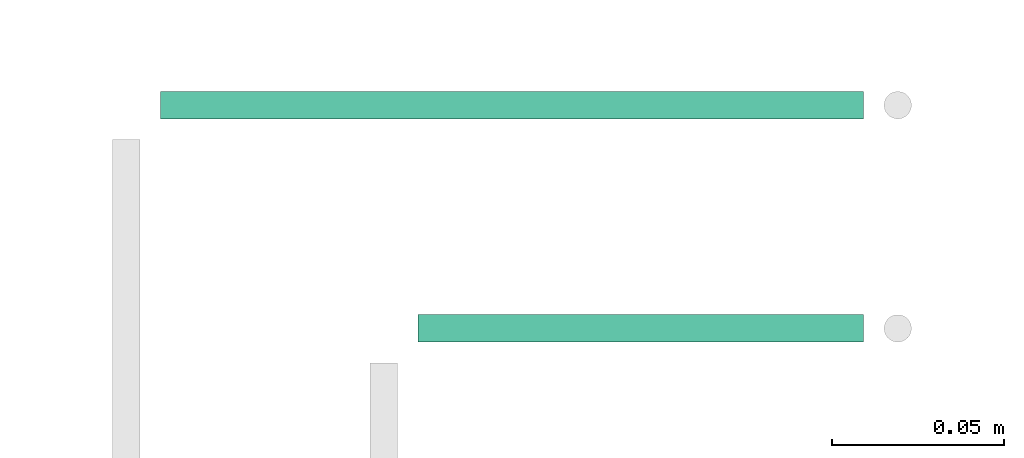
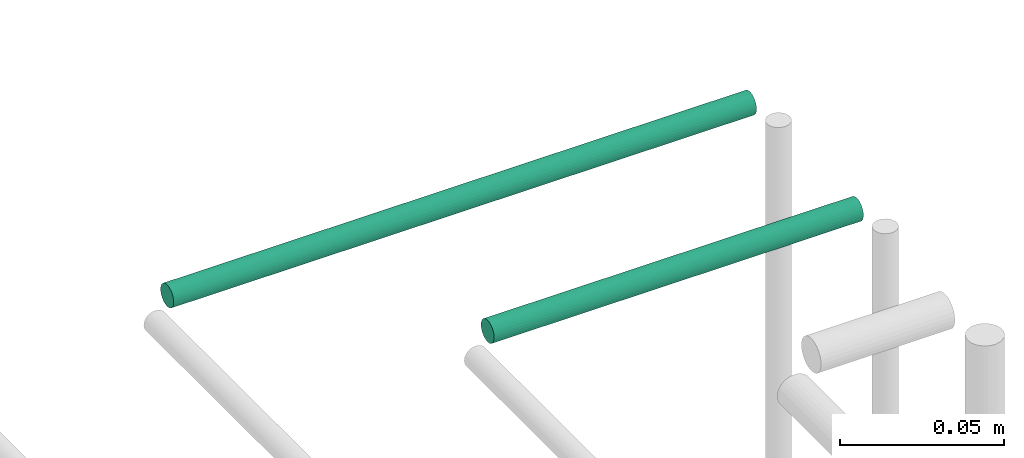
# One storey, part 239 of 331: 2 flow segments.
"""IFC2X3 building model written with IfcOpenShell, lengths in millimetres."""

import ifcopenshell
import ifcopenshell.guid

model = None  # the IFC model being written
_history = None  # IfcOwnerHistory: only IFC2X3 demands one
_inside = {}  # id of a spatial element -> (the spatial element, [elements in it])
_under = {}  # id of a project, library or spatial element -> (it, [spatial elements below it])
_declared = {}  # id of a project -> (the project, [libraries it declares])
_typed = {}  # id of a type object -> (the type object, [elements of that type])
_made_of = {}  # id of a material, layer set ... -> (it, [elements and type objects made of it])


def new_model(schema):
    """Start an empty IFC model of exactly this schema.

    Asked for "IFC4X3", IfcOpenShell would pick the latest addendum, in which some entities
    have other attributes; the version numbers below select the first issue.
    IFC2X3 requires an IfcOwnerHistory on every rooted entity: one is made here for all.
    """
    global model, _history
    if schema == "IFC4X3":
        model = ifcopenshell.file(schema_version=(4, 3, 0, 0))
    else:
        model = ifcopenshell.file(schema=schema)
    _inside.clear()
    _under.clear()
    _declared.clear()
    _typed.clear()
    _made_of.clear()
    _history = None
    if model.schema == "IFC2X3":
        org = make("IfcOrganization", Name="unknown")
        user = make(
            "IfcPersonAndOrganization",
            ThePerson=make("IfcPerson", FamilyName="unknown"),
            TheOrganization=org,
        )
        app = make(
            "IfcApplication",
            ApplicationDeveloper=org,
            Version="unknown",
            ApplicationFullName="unknown",
            ApplicationIdentifier="unknown",
        )
        _history = make(
            "IfcOwnerHistory",
            OwningUser=user,
            OwningApplication=app,
            ChangeAction="ADDED",
            CreationDate=0,
        )
    return model


def make(cls, **values):
    """One entity of the class cls with the attributes given. An attribute that is None is left unset."""
    return model.create_entity(
        cls, **{name: value for name, value in values.items() if value is not None}
    )


def entity(cls, *values):
    """Any entity or typed value of the class cls, its attributes in the order of the schema. None: left unset."""
    e = model.create_entity(cls)
    for i, value in enumerate(values):
        if value is not None:
            e[i] = value
    return e


def rooted(cls, **values):
    """An entity with a GlobalId (a new one), such as an element, a storey or a relation."""
    return make(cls, GlobalId=ifcopenshell.guid.new(), OwnerHistory=_history, **values)


def si_unit(unit_type, name, prefix=None):
    """IfcSIUnit, for example si_unit("LENGTHUNIT", "METRE", prefix="MILLI")."""
    return make("IfcSIUnit", UnitType=unit_type, Prefix=prefix, Name=name)


def converted_unit(unit_type, name, factor, base, dimensions=None, offset=None):
    """IfcConversionBasedUnit, such as the inch: factor (a typed value) times the base unit."""
    return make(
        "IfcConversionBasedUnit"
        if offset is None
        else "IfcConversionBasedUnitWithOffset",
        ConversionOffset=offset,
        Dimensions=None
        if dimensions is None
        else entity("IfcDimensionalExponents", *dimensions),
        UnitType=unit_type,
        Name=name,
        ConversionFactor=make(
            "IfcMeasureWithUnit", ValueComponent=factor, UnitComponent=base
        ),
    )


def derived_unit(unit_type, elements):
    """IfcDerivedUnit: a product of units, each with its exponent."""
    return make(
        "IfcDerivedUnit",
        Elements=[
            make("IfcDerivedUnitElement", Unit=unit, Exponent=power)
            for unit, power in elements
        ],
        UnitType=unit_type,
    )


def assignment(units):
    """IfcUnitAssignment: the units of a project."""
    return None if units is None else make("IfcUnitAssignment", Units=units)


def point(xyz):
    """IfcCartesianPoint."""
    return None if xyz is None else make("IfcCartesianPoint", Coordinates=xyz)


def direction(xyz):
    """IfcDirection."""
    return None if xyz is None else make("IfcDirection", DirectionRatios=xyz)


def frame(location, z_axis=None, x_axis=None):
    """IfcAxis2Placement3D, a coordinate frame: its origin and axes. An axis left out is left unset."""
    return make(
        "IfcAxis2Placement3D",
        Location=point(location),
        Axis=direction(z_axis),
        RefDirection=direction(x_axis),
    )


def frame_2d(location, x_axis=None):
    """IfcAxis2Placement2D, a coordinate frame in the plane: its origin and x axis."""
    return make(
        "IfcAxis2Placement2D", Location=point(location), RefDirection=direction(x_axis)
    )


def origin():
    """The frame at (0, 0, 0) with its axes left unset."""
    return frame((0.0, 0.0, 0.0))


def origin_2d_with_axis():
    """The frame at (0, 0) in the plane with the x axis (1, 0) written out."""
    return frame_2d((0.0, 0.0), x_axis=(1.0, 0.0))


def place(relative_to, where):
    """IfcLocalPlacement: puts the frame where relative to a parent placement (None: the world)."""
    return make(
        "IfcLocalPlacement", PlacementRelTo=relative_to, RelativePlacement=where
    )


def context(
    kind, dimensions, precision=None, world=None, true_north=None, identifier=None
):
    """IfcGeometricRepresentationContext, for example the 3D "Model" context."""
    return make(
        "IfcGeometricRepresentationContext",
        ContextIdentifier=identifier,
        ContextType=kind,
        CoordinateSpaceDimension=dimensions,
        Precision=precision,
        WorldCoordinateSystem=world,
        TrueNorth=true_north,
    )


def subcontext(parent, identifier, kind, view, scale=None):
    """IfcGeometricRepresentationSubContext, for example "Body" below "Model"."""
    return make(
        "IfcGeometricRepresentationSubContext",
        ContextIdentifier=identifier,
        ContextType=kind,
        ParentContext=parent,
        TargetScale=scale,
        TargetView=view,
    )


def project(units=None, contexts=None):
    """IfcProject with its units and contexts."""
    return rooted(
        "IfcProject",
        Name="project",
        RepresentationContexts=contexts,
        UnitsInContext=assignment(units),
    )


def spatial(cls, under=None, at=None, **own):
    """A site, building, storey or space (cls), placed at a placement, below another one or the project."""
    s = rooted(cls, ObjectPlacement=at, **own)
    if under is not None:
        _under.setdefault(under.id(), (under, []))[1].append(s)
    return s


def profile(cls, at=None, kind="AREA", **sizes):
    """A parametric profile (cls). Its sizes go by their IFC names, for example OverallWidth=200.0."""
    return make(cls, ProfileType=kind, Position=at, **sizes)


def circle(**sizes):
    """IfcCircleProfileDef."""
    return profile("IfcCircleProfileDef", **sizes)


def extrude(swept, where, along, depth):
    """IfcExtrudedAreaSolid: the profile swept, set in the frame where, extruded along a direction by depth."""
    return make(
        "IfcExtrudedAreaSolid",
        SweptArea=swept,
        Position=where,
        ExtrudedDirection=direction(along),
        Depth=depth,
    )


def shape(context_of_items, identifier, shape_type, items):
    """IfcShapeRepresentation: the items that make up one representation, for example the "Body"."""
    return make(
        "IfcShapeRepresentation",
        ContextOfItems=context_of_items,
        RepresentationIdentifier=identifier,
        RepresentationType=shape_type,
        Items=items,
    )


def made_of(thing, what):
    """Note that an element or type object is made of a material, layer set ...; save() writes the relation."""
    if what is not None:
        _made_of.setdefault(what.id(), (what, []))[1].append(thing)
    return thing


def type_object(cls, material=None, **own):
    """A type object (cls), such as IfcWallType, which elements share."""
    return made_of(rooted(cls, **own), material)


def element(
    cls,
    number,
    at=None,
    inside=None,
    cuts=None,
    type_object=None,
    material=None,
    context=None,
    identifier="Body",
    shape_type=None,
    held_by="IfcProductDefinitionShape",
    body=None,
    shapes=None,
    **own,
):
    """One element of the class cls, such as IfcWall. Its Tag is "e" and its number.

    at: its placement. inside: the storey or other place that contains it. cuts: it is an
    opening in that element (IfcRelVoidsElement). A single representation is given by context,
    identifier, shape_type and body (its items); several are given by shapes. held_by: the class
    of the entity that holds the representations. save() writes the other relations.
    """
    e = rooted(cls, Tag="e%d" % number, ObjectPlacement=at, **own)
    if body is not None:
        shapes = [shape(context, identifier, shape_type, body)]
    if shapes is not None:
        e.Representation = make(held_by, Representations=shapes)
    if inside is not None:
        _inside.setdefault(inside.id(), (inside, []))[1].append(e)
    if cuts is not None:
        rooted(
            "IfcRelVoidsElement", RelatingBuildingElement=cuts, RelatedOpeningElement=e
        )
    if type_object is not None:
        _typed.setdefault(type_object.id(), (type_object, []))[1].append(e)
    return made_of(e, material)


def aggregate(whole, parts):
    """IfcRelAggregates: a whole, such as a stair, and the parts it consists of."""
    return rooted("IfcRelAggregates", RelatingObject=whole, RelatedObjects=parts)


def save(model, path):
    """Write the relations noted so far, then the file.

    IfcRelAggregates (storeys below a building ...), IfcRelContainedInSpatialStructure (elements
    in a storey), IfcRelDefinesByType, IfcRelAssociatesMaterial and IfcRelDeclares: one each for
    every whole, place, type object, material and project.
    """
    for whole, parts in _under.values():
        aggregate(whole, parts)
    for where, things in _inside.values():
        rooted(
            "IfcRelContainedInSpatialStructure",
            RelatedElements=things,
            RelatingStructure=where,
        )
    for kind, things in _typed.values():
        rooted("IfcRelDefinesByType", RelatedObjects=things, RelatingType=kind)
    for what, things in _made_of.values():
        rooted("IfcRelAssociatesMaterial", RelatedObjects=things, RelatingMaterial=what)
    for by, libraries in _declared.values():
        rooted("IfcRelDeclares", RelatingContext=by, RelatedDefinitions=libraries)
    model.write(path)


model = new_model("IFC2X3")

# Units and contexts
model_context = context("Model", 3, precision=0.01, world=origin(), true_north=direction((6.12303176911189e-17, 1.0)))
body_context = subcontext(model_context, "Body", "Model", "MODEL_VIEW")
ifc_project = project(units=[si_unit("LENGTHUNIT", "METRE", prefix="MILLI"), si_unit("AREAUNIT", "SQUARE_METRE"), si_unit("VOLUMEUNIT", "CUBIC_METRE"), converted_unit("PLANEANGLEUNIT", "DEGREE", entity("IfcRatioMeasure", 0.0174532925199433), si_unit("PLANEANGLEUNIT", "RADIAN"), dimensions=[0, 0, 0, 0, 0, 0, 0]), si_unit("MASSUNIT", "GRAM", prefix="KILO"), derived_unit("MASSDENSITYUNIT", [(si_unit("MASSUNIT", "GRAM", prefix="KILO"), 1), (si_unit("LENGTHUNIT", "METRE"), -3)]), derived_unit("MOMENTOFINERTIAUNIT", [(si_unit("LENGTHUNIT", "METRE"), 4)]), si_unit("TIMEUNIT", "SECOND"), si_unit("FREQUENCYUNIT", "HERTZ"), si_unit("THERMODYNAMICTEMPERATUREUNIT", "DEGREE_CELSIUS"), derived_unit("THERMALTRANSMITTANCEUNIT", [(si_unit("MASSUNIT", "GRAM", prefix="KILO"), 1), (si_unit("THERMODYNAMICTEMPERATUREUNIT", "KELVIN"), -1), (si_unit("TIMEUNIT", "SECOND"), -3)]), derived_unit("VOLUMETRICFLOWRATEUNIT", [(si_unit("LENGTHUNIT", "METRE"), 3), (si_unit("TIMEUNIT", "SECOND"), -1)]), derived_unit("MASSFLOWRATEUNIT", [(si_unit("MASSUNIT", "GRAM", prefix="KILO"), 1), (si_unit("TIMEUNIT", "SECOND"), -1)]), derived_unit("ROTATIONALFREQUENCYUNIT", [(si_unit("TIMEUNIT", "SECOND"), -1)]), si_unit("ELECTRICCURRENTUNIT", "AMPERE"), si_unit("ELECTRICVOLTAGEUNIT", "VOLT"), si_unit("POWERUNIT", "WATT"), si_unit("FORCEUNIT", "NEWTON", prefix="KILO"), si_unit("ILLUMINANCEUNIT", "LUX"), si_unit("LUMINOUSFLUXUNIT", "LUMEN"), si_unit("LUMINOUSINTENSITYUNIT", "CANDELA"), derived_unit("USERDEFINED", [(si_unit("MASSUNIT", "GRAM", prefix="KILO"), -1), (si_unit("LENGTHUNIT", "METRE"), -2), (si_unit("TIMEUNIT", "SECOND"), 3), (si_unit("LUMINOUSFLUXUNIT", "LUMEN"), 1)]), derived_unit("LINEARVELOCITYUNIT", [(si_unit("LENGTHUNIT", "METRE"), 1), (si_unit("TIMEUNIT", "SECOND"), -1)]), si_unit("PRESSUREUNIT", "PASCAL"), derived_unit("USERDEFINED", [(si_unit("LENGTHUNIT", "METRE"), -2), (si_unit("MASSUNIT", "GRAM", prefix="KILO"), 1), (si_unit("TIMEUNIT", "SECOND"), -2)]), derived_unit("LINEARFORCEUNIT", [(si_unit("MASSUNIT", "GRAM", prefix="KILO"), 1), (si_unit("LENGTHUNIT", "METRE"), 1), (si_unit("TIMEUNIT", "SECOND"), -2), (si_unit("LENGTHUNIT", "METRE"), -1)]), derived_unit("PLANARFORCEUNIT", [(si_unit("MASSUNIT", "GRAM", prefix="KILO"), 1), (si_unit("LENGTHUNIT", "METRE"), 1), (si_unit("TIMEUNIT", "SECOND"), -2), (si_unit("LENGTHUNIT", "METRE"), -2)])], contexts=[model_context])

# Site, building, storey
site_placement = place(None, frame((0.0, -0.00077364408347762, 0.0)))
site = spatial("IfcSite", under=ifc_project, at=site_placement, CompositionType="ELEMENT")
building_placement = place(site_placement, origin())
building = spatial("IfcBuilding", under=site, at=building_placement, CompositionType="ELEMENT")
storey_placement = place(building_placement, origin())
storey = spatial("IfcBuildingStorey", under=building, at=storey_placement, CompositionType="ELEMENT", Elevation=0.0)

# Flow segments
pipe_segment_type = type_object("IfcPipeSegmentType", PredefinedType="NOTDEFINED")
flow_segment_1_placement = place(storey_placement, frame((41455.0006958009, 19557.6765034793, 7344.40472776408)))
element("IfcFlowSegment", 1, at=flow_segment_1_placement, inside=storey, type_object=pipe_segment_type, context=body_context, shape_type="SweptSolid", body=[
    extrude(circle(Radius=4.0, at=origin_2d_with_axis()), frame((0.0, 5.59527223591499, 5.59527223591607), z_axis=(1.0, 0.0, 0.0), x_axis=(0.0, -1.0, 0.0)), (0.0, 0.0, 1.0), 129.661160939976),
])
flow_segment_2_placement = place(storey_placement, frame((41380.0006958009, 19622.6765034793, 7344.40472776408)))
element("IfcFlowSegment", 2, at=flow_segment_2_placement, inside=storey, type_object=pipe_segment_type, context=body_context, shape_type="SweptSolid", body=[
    extrude(circle(Radius=4.0, at=origin_2d_with_axis()), frame((0.0, 5.59527223591499, 5.59527223591607), z_axis=(1.0, 0.0, 0.0), x_axis=(0.0, -1.0, 0.0)), (0.0, 0.0, 1.0), 204.661160939968),
])

save(model, "model.ifc")
